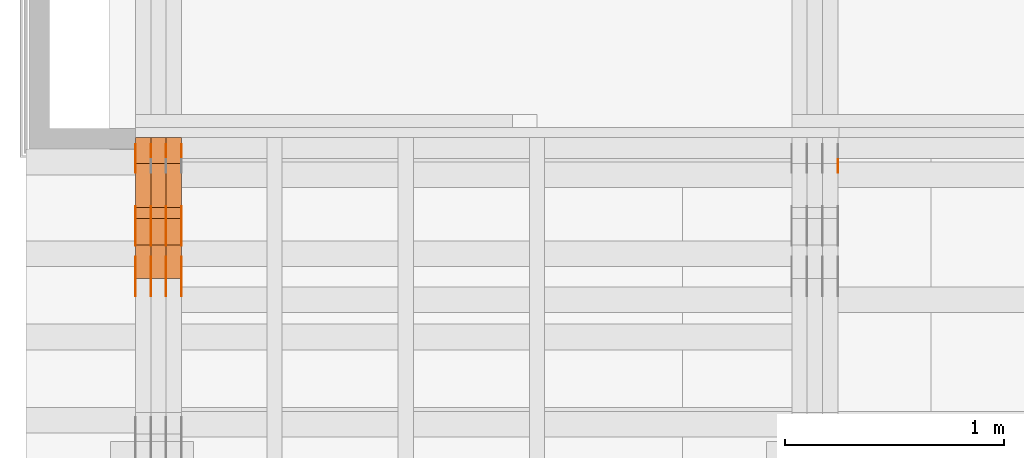
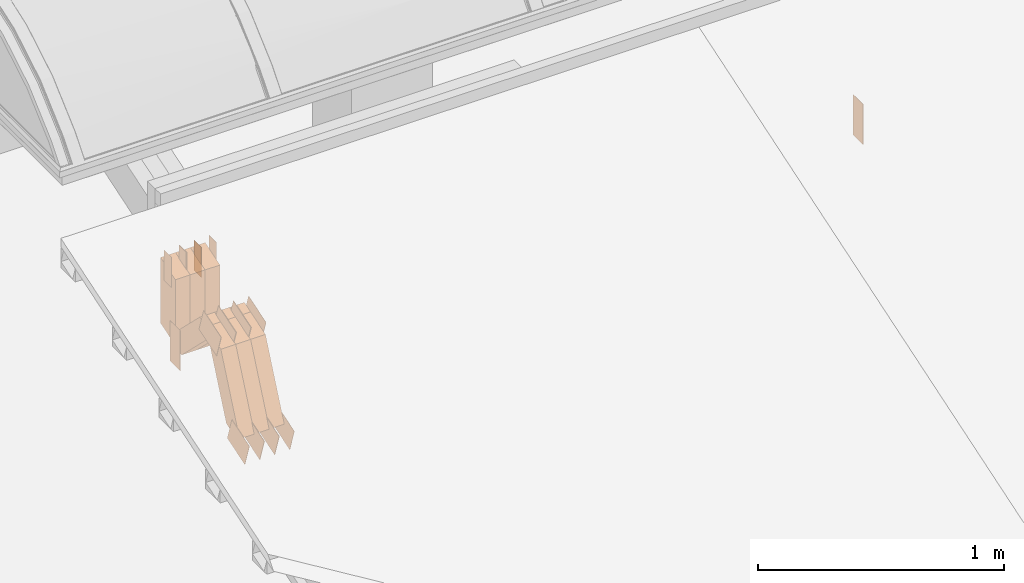
# One storey, part 77 of 385: 29 proxies.
"""IFC2X3 building model written with IfcOpenShell, lengths in millimetres."""

from ifc_helpers import new_model, entity, si_unit, converted_unit, derived_unit, direction, frame, frame_2d, origin, origin_2d_with_axis, place, context, subcontext, project, spatial, polyline, rectangle, outline, extrude, source, transform, mapped, material, type_object, type_shapes, element, save


model = new_model("IFC2X3")

# Units and contexts
model_context = context("Model", 3, precision=0.01, world=origin(), true_north=direction((6.12303176911189e-17, 1.0)))
body_context = subcontext(model_context, "Body", "Model", "MODEL_VIEW")
ifc_project = project(units=[si_unit("LENGTHUNIT", "METRE", prefix="MILLI"), si_unit("AREAUNIT", "SQUARE_METRE"), si_unit("VOLUMEUNIT", "CUBIC_METRE"), converted_unit("PLANEANGLEUNIT", "DEGREE", entity("IfcRatioMeasure", 0.0174532925199433), si_unit("PLANEANGLEUNIT", "RADIAN"), dimensions=[0, 0, 0, 0, 0, 0, 0]), si_unit("MASSUNIT", "GRAM", prefix="KILO"), derived_unit("MASSDENSITYUNIT", [(si_unit("MASSUNIT", "GRAM", prefix="KILO"), 1), (si_unit("LENGTHUNIT", "METRE"), -3)]), si_unit("TIMEUNIT", "SECOND"), si_unit("FREQUENCYUNIT", "HERTZ"), si_unit("THERMODYNAMICTEMPERATUREUNIT", "DEGREE_CELSIUS"), derived_unit("THERMALTRANSMITTANCEUNIT", [(si_unit("MASSUNIT", "GRAM", prefix="KILO"), 1), (si_unit("THERMODYNAMICTEMPERATUREUNIT", "KELVIN"), -1), (si_unit("TIMEUNIT", "SECOND"), -3)]), derived_unit("VOLUMETRICFLOWRATEUNIT", [(si_unit("LENGTHUNIT", "METRE"), 3), (si_unit("TIMEUNIT", "SECOND"), -1)]), si_unit("ELECTRICCURRENTUNIT", "AMPERE"), si_unit("ELECTRICVOLTAGEUNIT", "VOLT"), si_unit("POWERUNIT", "WATT"), si_unit("FORCEUNIT", "NEWTON", prefix="KILO"), si_unit("ILLUMINANCEUNIT", "LUX"), si_unit("LUMINOUSFLUXUNIT", "LUMEN"), si_unit("LUMINOUSINTENSITYUNIT", "CANDELA"), derived_unit("USERDEFINED", [(si_unit("MASSUNIT", "GRAM", prefix="KILO"), -1), (si_unit("LENGTHUNIT", "METRE"), -2), (si_unit("TIMEUNIT", "SECOND"), 3), (si_unit("LUMINOUSFLUXUNIT", "LUMEN"), 1)]), derived_unit("LINEARVELOCITYUNIT", [(si_unit("LENGTHUNIT", "METRE"), 1), (si_unit("TIMEUNIT", "SECOND"), -1)]), si_unit("PRESSUREUNIT", "PASCAL"), derived_unit("USERDEFINED", [(si_unit("LENGTHUNIT", "METRE"), -2), (si_unit("MASSUNIT", "GRAM", prefix="KILO"), 1), (si_unit("TIMEUNIT", "SECOND"), -2)])], contexts=[model_context])

# Site, building, storey
site_placement = place(None, origin())
site = spatial("IfcSite", under=ifc_project, at=site_placement, CompositionType="ELEMENT")
building_placement = place(site_placement, origin())
building = spatial("IfcBuilding", under=site, at=building_placement, CompositionType="ELEMENT")
storey_placement = place(building_placement, origin())
storey = spatial("IfcBuildingStorey", under=building, at=storey_placement, Name="Default", CompositionType="ELEMENT", Elevation=0.0)

# Proxies
ifc_material_1 = material(Name="IfcSurfaceStyle #71412")
building_element_proxy_type_1 = type_object("IfcBuildingElementProxyType", PredefinedType="NOTDEFINED", material=ifc_material_1)
shared_shape_1 = source(origin(), body_context, "Body", "SweptSolid", [
    extrude(rectangle(XDim=200.0, YDim=84.0, at=frame_2d((0.0, -7.105427357601e-15), x_axis=(1.0, 0.0))), frame((100.0, 42.0, 0.0), z_axis=(0.0, 0.0, 1.0), x_axis=(-1.0, 0.0, 0.0)), (0.0, 0.0, 1.0), 1.3),
])
type_shapes(building_element_proxy_type_1, [shared_shape_1])
proxy_1_placement = place(building_placement, frame((3386.29999999999, 13702.0, 3651.4150390625), z_axis=(-1.0, 0.0, 0.0), x_axis=(0.0, 0.0, -1.0)))
element("IfcBuildingElementProxy", 1, at=proxy_1_placement, inside=storey, type_object=building_element_proxy_type_1, material=ifc_material_1, context=body_context, shape_type="MappedRepresentation", body=[
    mapped(shared_shape_1, transform((0.0, 0.0, 0.0), scale=1.0)),
])
ifc_material_2 = material(Name="IfcSurfaceStyle #36695")
building_element_proxy_type_2 = type_object("IfcBuildingElementProxyType", PredefinedType="NOTDEFINED", material=ifc_material_2)
shared_shape_2 = source(origin(), body_context, "Body", "SweptSolid", [
    extrude(rectangle(XDim=200.0, YDim=84.0, at=frame_2d((0.0, -7.105427357601e-15), x_axis=(1.0, 0.0))), frame((100.0, 42.0, 0.0), z_axis=(0.0, 0.0, 1.0), x_axis=(-1.0, 0.0, 0.0)), (0.0, 0.0, 1.0), 1.29999999999999),
])
type_shapes(building_element_proxy_type_2, [shared_shape_2])
proxy_2_placement = place(building_placement, frame((175.0, 13702.0, 3651.4150390625), z_axis=(-1.0, 0.0, 0.0), x_axis=(0.0, 0.0, -1.0)))
element("IfcBuildingElementProxy", 2, at=proxy_2_placement, inside=storey, type_object=building_element_proxy_type_2, material=ifc_material_2, context=body_context, shape_type="MappedRepresentation", body=[
    mapped(shared_shape_2, transform((0.0, 0.0, 0.0), scale=1.0)),
])
ifc_material_3 = material(Name="IfcSurfaceStyle #36638")
building_element_proxy_type_3 = type_object("IfcBuildingElementProxyType", PredefinedType="NOTDEFINED", material=ifc_material_3)
shared_shape_3 = source(origin(), body_context, "Body", "SweptSolid", [
    extrude(outline(polyline([(-75.0003398116828, -59.9998507501386), (75.0003249421766, -59.9998507501386), (75.0003398116837, 59.9998507501387), (-75.0003249421775, 59.9998507501387), (-75.0003398116828, -59.9998507501386)])), frame((75.0003398116837, 60.0000773549637, 0.0), z_axis=(0.0, 0.0, 1.0), x_axis=(-1.0, 0.0, 0.0)), (0.0, 0.0, 1.0), 1.3),
])
type_shapes(building_element_proxy_type_3, [shared_shape_3])
proxy_3_placement = place(building_placement, frame((386.299999999986, 13054.73046875, 3417.8388671875), z_axis=(-1.0, 0.0, 0.0), x_axis=(0.0, 0.951056516295124, 0.309016994375039)))
element("IfcBuildingElementProxy", 3, at=proxy_3_placement, inside=storey, type_object=building_element_proxy_type_3, material=ifc_material_3, context=body_context, shape_type="MappedRepresentation", body=[
    mapped(shared_shape_3, transform((0.0, 0.0, 0.0), scale=1.0)),
])
ifc_material_4 = material(Name="IfcSurfaceStyle #36581")
building_element_proxy_type_4 = type_object("IfcBuildingElementProxyType", PredefinedType="NOTDEFINED", material=ifc_material_4)
shared_shape_4 = source(origin(), body_context, "Body", "SweptSolid", [
    extrude(outline(polyline([(-75.0003398116828, -59.9998507501386), (75.0003249421766, -59.9998507501386), (75.0003398116837, 59.9998507501387), (-75.0003249421775, 59.9998507501387), (-75.0003398116828, -59.9998507501386)])), frame((75.0003398116837, 60.0000773549637, 0.0), z_axis=(0.0, 0.0, 1.0), x_axis=(-1.0, 0.0, 0.0)), (0.0, 0.0, 1.0), 1.3),
])
type_shapes(building_element_proxy_type_4, [shared_shape_4])
proxy_4_placement = place(building_placement, frame((315.0, 13054.73046875, 3417.8388671875), z_axis=(-1.0, 0.0, 0.0), x_axis=(0.0, 0.951056516295124, 0.309016994375039)))
element("IfcBuildingElementProxy", 4, at=proxy_4_placement, inside=storey, type_object=building_element_proxy_type_4, material=ifc_material_4, context=body_context, shape_type="MappedRepresentation", body=[
    mapped(shared_shape_4, transform((0.0, 0.0, 0.0), scale=1.0)),
])
ifc_material_5 = material(Name="IfcSurfaceStyle #36524")
building_element_proxy_type_5 = type_object("IfcBuildingElementProxyType", PredefinedType="NOTDEFINED", material=ifc_material_5)
shared_shape_5 = source(origin(), body_context, "Body", "SweptSolid", [
    extrude(outline(polyline([(-75.0003398116828, -59.9998507501386), (75.0003249421766, -59.9998507501386), (75.0003398116837, 59.9998507501387), (-75.0003249421775, 59.9998507501387), (-75.0003398116828, -59.9998507501386)])), frame((75.0003398116837, 60.0000773549637, 0.0), z_axis=(0.0, 0.0, 1.0), x_axis=(-1.0, 0.0, 0.0)), (0.0, 0.0, 1.0), 1.3),
])
type_shapes(building_element_proxy_type_5, [shared_shape_5])
proxy_5_placement = place(building_placement, frame((316.299999999986, 13054.73046875, 3417.8388671875), z_axis=(-1.0, 0.0, 0.0), x_axis=(0.0, 0.951056516295124, 0.309016994375039)))
element("IfcBuildingElementProxy", 5, at=proxy_5_placement, inside=storey, type_object=building_element_proxy_type_5, material=ifc_material_5, context=body_context, shape_type="MappedRepresentation", body=[
    mapped(shared_shape_5, transform((0.0, 0.0, 0.0), scale=1.0)),
])
ifc_material_6 = material(Name="IfcSurfaceStyle #36467")
building_element_proxy_type_6 = type_object("IfcBuildingElementProxyType", PredefinedType="NOTDEFINED", material=ifc_material_6)
shared_shape_6 = source(origin(), body_context, "Body", "SweptSolid", [
    extrude(outline(polyline([(-75.0003398116828, -59.9998507501386), (75.0003249421766, -59.9998507501386), (75.0003398116837, 59.9998507501387), (-75.0003249421775, 59.9998507501387), (-75.0003398116828, -59.9998507501386)])), frame((75.0003398116837, 60.0000773549637, 0.0), z_axis=(0.0, 0.0, 1.0), x_axis=(-1.0, 0.0, 0.0)), (0.0, 0.0, 1.0), 1.29999999999999),
])
type_shapes(building_element_proxy_type_6, [shared_shape_6])
proxy_6_placement = place(building_placement, frame((245.0, 13054.73046875, 3417.8388671875), z_axis=(-1.0, 0.0, 0.0), x_axis=(0.0, 0.951056516295124, 0.309016994375039)))
element("IfcBuildingElementProxy", 6, at=proxy_6_placement, inside=storey, type_object=building_element_proxy_type_6, material=ifc_material_6, context=body_context, shape_type="MappedRepresentation", body=[
    mapped(shared_shape_6, transform((0.0, 0.0, 0.0), scale=1.0)),
])
ifc_material_7 = material(Name="IfcSurfaceStyle #36410")
building_element_proxy_type_7 = type_object("IfcBuildingElementProxyType", PredefinedType="NOTDEFINED", material=ifc_material_7)
shared_shape_7 = source(origin(), body_context, "Body", "SweptSolid", [
    extrude(outline(polyline([(-75.0003398116828, -59.9998507501386), (75.0003249421766, -59.9998507501386), (75.0003398116837, 59.9998507501387), (-75.0003249421775, 59.9998507501387), (-75.0003398116828, -59.9998507501386)])), frame((75.0003398116837, 60.0000773549637, 0.0), z_axis=(0.0, 0.0, 1.0), x_axis=(-1.0, 0.0, 0.0)), (0.0, 0.0, 1.0), 1.29999999999999),
])
type_shapes(building_element_proxy_type_7, [shared_shape_7])
proxy_7_placement = place(building_placement, frame((246.299999999986, 13054.73046875, 3417.8388671875), z_axis=(-1.0, 0.0, 0.0), x_axis=(0.0, 0.951056516295124, 0.309016994375039)))
element("IfcBuildingElementProxy", 7, at=proxy_7_placement, inside=storey, type_object=building_element_proxy_type_7, material=ifc_material_7, context=body_context, shape_type="MappedRepresentation", body=[
    mapped(shared_shape_7, transform((0.0, 0.0, 0.0), scale=1.0)),
])
ifc_material_8 = material(Name="IfcSurfaceStyle #36353")
building_element_proxy_type_8 = type_object("IfcBuildingElementProxyType", PredefinedType="NOTDEFINED", material=ifc_material_8)
shared_shape_8 = source(origin(), body_context, "Body", "SweptSolid", [
    extrude(outline(polyline([(-75.0003398116828, -59.9998507501386), (75.0003249421766, -59.9998507501386), (75.0003398116837, 59.9998507501387), (-75.0003249421775, 59.9998507501387), (-75.0003398116828, -59.9998507501386)])), frame((75.0003398116837, 60.0000773549637, 0.0), z_axis=(0.0, 0.0, 1.0), x_axis=(-1.0, 0.0, 0.0)), (0.0, 0.0, 1.0), 1.29999999999999),
])
type_shapes(building_element_proxy_type_8, [shared_shape_8])
proxy_8_placement = place(building_placement, frame((175.0, 13054.73046875, 3417.8388671875), z_axis=(-1.0, 0.0, 0.0), x_axis=(0.0, 0.951056516295124, 0.309016994375039)))
element("IfcBuildingElementProxy", 8, at=proxy_8_placement, inside=storey, type_object=building_element_proxy_type_8, material=ifc_material_8, context=body_context, shape_type="MappedRepresentation", body=[
    mapped(shared_shape_8, transform((0.0, 0.0, 0.0), scale=1.0)),
])
ifc_material_9 = material(Name="IfcSurfaceStyle #28772")
building_element_proxy_type_9 = type_object("IfcBuildingElementProxyType", PredefinedType="NOTDEFINED", material=ifc_material_9)
shared_shape_9 = source(origin(), body_context, "Body", "SweptSolid", [
    extrude(outline(polyline([(-74.999875428623, -60.0000016373506), (74.9998605591059, -60.0000016373506), (74.9998754286239, 60.0000016373506), (-74.9998605591068, 60.0000016373506), (-74.999875428623, -60.0000016373506)])), frame((75.0002691827262, 60.0000190504561, 0.0), z_axis=(0.0, 0.0, 1.0), x_axis=(-1.0, 0.0, 0.0)), (0.0, 0.0, 1.0), 1.3),
])
type_shapes(building_element_proxy_type_9, [shared_shape_9])
proxy_9_placement = place(building_placement, frame((386.299999999986, 13285.0865109705, 3819.37496637467), z_axis=(-1.0, 0.0, 0.0), x_axis=(0.0, 0.951056516295154, 0.309016994374948)))
element("IfcBuildingElementProxy", 9, at=proxy_9_placement, inside=storey, type_object=building_element_proxy_type_9, material=ifc_material_9, context=body_context, shape_type="MappedRepresentation", body=[
    mapped(shared_shape_9, transform((0.0, 0.0, 0.0), scale=1.0)),
])
ifc_material_10 = material(Name="IfcSurfaceStyle #28715")
building_element_proxy_type_10 = type_object("IfcBuildingElementProxyType", PredefinedType="NOTDEFINED", material=ifc_material_10)
shared_shape_10 = source(origin(), body_context, "Body", "SweptSolid", [
    extrude(outline(polyline([(-74.999875428623, -60.0000016373506), (74.9998605591059, -60.0000016373506), (74.9998754286239, 60.0000016373506), (-74.9998605591068, 60.0000016373506), (-74.999875428623, -60.0000016373506)])), frame((75.0002691827262, 60.0000190504561, 0.0), z_axis=(0.0, 0.0, 1.0), x_axis=(-1.0, 0.0, 0.0)), (0.0, 0.0, 1.0), 1.3),
])
type_shapes(building_element_proxy_type_10, [shared_shape_10])
proxy_10_placement = place(building_placement, frame((315.0, 13285.0865109705, 3819.37496637467), z_axis=(-1.0, 0.0, 0.0), x_axis=(0.0, 0.951056516295154, 0.309016994374948)))
element("IfcBuildingElementProxy", 10, at=proxy_10_placement, inside=storey, type_object=building_element_proxy_type_10, material=ifc_material_10, context=body_context, shape_type="MappedRepresentation", body=[
    mapped(shared_shape_10, transform((0.0, 0.0, 0.0), scale=1.0)),
])
ifc_material_11 = material(Name="IfcSurfaceStyle #28658")
building_element_proxy_type_11 = type_object("IfcBuildingElementProxyType", PredefinedType="NOTDEFINED", material=ifc_material_11)
shared_shape_11 = source(origin(), body_context, "Body", "SweptSolid", [
    extrude(outline(polyline([(-74.999875428623, -60.0000016373506), (74.9998605591059, -60.0000016373506), (74.9998754286239, 60.0000016373506), (-74.9998605591068, 60.0000016373506), (-74.999875428623, -60.0000016373506)])), frame((75.0002691827262, 60.0000190504561, 0.0), z_axis=(0.0, 0.0, 1.0), x_axis=(-1.0, 0.0, 0.0)), (0.0, 0.0, 1.0), 1.3),
])
type_shapes(building_element_proxy_type_11, [shared_shape_11])
proxy_11_placement = place(building_placement, frame((316.299999999986, 13285.0865109705, 3819.37496637467), z_axis=(-1.0, 0.0, 0.0), x_axis=(0.0, 0.951056516295154, 0.309016994374948)))
element("IfcBuildingElementProxy", 11, at=proxy_11_placement, inside=storey, type_object=building_element_proxy_type_11, material=ifc_material_11, context=body_context, shape_type="MappedRepresentation", body=[
    mapped(shared_shape_11, transform((0.0, 0.0, 0.0), scale=1.0)),
])
ifc_material_12 = material(Name="IfcSurfaceStyle #28601")
building_element_proxy_type_12 = type_object("IfcBuildingElementProxyType", PredefinedType="NOTDEFINED", material=ifc_material_12)
shared_shape_12 = source(origin(), body_context, "Body", "SweptSolid", [
    extrude(outline(polyline([(-74.999875428623, -60.0000016373506), (74.9998605591059, -60.0000016373506), (74.9998754286239, 60.0000016373506), (-74.9998605591068, 60.0000016373506), (-74.999875428623, -60.0000016373506)])), frame((75.0002691827262, 60.0000190504561, 0.0), z_axis=(0.0, 0.0, 1.0), x_axis=(-1.0, 0.0, 0.0)), (0.0, 0.0, 1.0), 1.29999999999999),
])
type_shapes(building_element_proxy_type_12, [shared_shape_12])
proxy_12_placement = place(building_placement, frame((245.0, 13285.0865109705, 3819.37496637467), z_axis=(-1.0, 0.0, 0.0), x_axis=(0.0, 0.951056516295154, 0.309016994374948)))
element("IfcBuildingElementProxy", 12, at=proxy_12_placement, inside=storey, type_object=building_element_proxy_type_12, material=ifc_material_12, context=body_context, shape_type="MappedRepresentation", body=[
    mapped(shared_shape_12, transform((0.0, 0.0, 0.0), scale=1.0)),
])
ifc_material_13 = material(Name="IfcSurfaceStyle #28544")
building_element_proxy_type_13 = type_object("IfcBuildingElementProxyType", PredefinedType="NOTDEFINED", material=ifc_material_13)
shared_shape_13 = source(origin(), body_context, "Body", "SweptSolid", [
    extrude(outline(polyline([(-74.999875428623, -60.0000016373506), (74.9998605591059, -60.0000016373506), (74.9998754286239, 60.0000016373506), (-74.9998605591068, 60.0000016373506), (-74.999875428623, -60.0000016373506)])), frame((75.0002691827262, 60.0000190504561, 0.0), z_axis=(0.0, 0.0, 1.0), x_axis=(-1.0, 0.0, 0.0)), (0.0, 0.0, 1.0), 1.29999999999999),
])
type_shapes(building_element_proxy_type_13, [shared_shape_13])
proxy_13_placement = place(building_placement, frame((246.299999999986, 13285.0865109705, 3819.37496637467), z_axis=(-1.0, 0.0, 0.0), x_axis=(0.0, 0.951056516295154, 0.309016994374948)))
element("IfcBuildingElementProxy", 13, at=proxy_13_placement, inside=storey, type_object=building_element_proxy_type_13, material=ifc_material_13, context=body_context, shape_type="MappedRepresentation", body=[
    mapped(shared_shape_13, transform((0.0, 0.0, 0.0), scale=1.0)),
])
ifc_material_14 = material(Name="IfcSurfaceStyle #28487")
building_element_proxy_type_14 = type_object("IfcBuildingElementProxyType", PredefinedType="NOTDEFINED", material=ifc_material_14)
shared_shape_14 = source(origin(), body_context, "Body", "SweptSolid", [
    extrude(outline(polyline([(-74.999875428623, -60.0000016373506), (74.9998605591059, -60.0000016373506), (74.9998754286239, 60.0000016373506), (-74.9998605591068, 60.0000016373506), (-74.999875428623, -60.0000016373506)])), frame((75.0002691827262, 60.0000190504561, 0.0), z_axis=(0.0, 0.0, 1.0), x_axis=(-1.0, 0.0, 0.0)), (0.0, 0.0, 1.0), 1.29999999999999),
])
type_shapes(building_element_proxy_type_14, [shared_shape_14])
proxy_14_placement = place(building_placement, frame((175.0, 13285.0865109705, 3819.37496637467), z_axis=(-1.0, 0.0, 0.0), x_axis=(0.0, 0.951056516295154, 0.309016994374948)))
element("IfcBuildingElementProxy", 14, at=proxy_14_placement, inside=storey, type_object=building_element_proxy_type_14, material=ifc_material_14, context=body_context, shape_type="MappedRepresentation", body=[
    mapped(shared_shape_14, transform((0.0, 0.0, 0.0), scale=1.0)),
])
ifc_material_15 = material(Name="IfcSurfaceStyle #28088")
building_element_proxy_type_15 = type_object("IfcBuildingElementProxyType", PredefinedType="NOTDEFINED", material=ifc_material_15)
shared_shape_15 = source(origin(), body_context, "Body", "SweptSolid", [
    extrude(rectangle(XDim=150.0, YDim=60.0, at=origin_2d_with_axis()), frame((75.0000705696166, 30.0, 0.0), z_axis=(0.0, 0.0, 1.0), x_axis=(-1.0, 0.0, 0.0)), (0.0, 0.0, 1.0), 1.3),
])
type_shapes(building_element_proxy_type_15, [shared_shape_15])
proxy_15_placement = place(building_placement, frame((386.299999999986, 13750.0, 3972.59919166337), z_axis=(-1.0, 0.0, 0.0), x_axis=(0.0, 0.0, -1.0)))
element("IfcBuildingElementProxy", 15, at=proxy_15_placement, inside=storey, type_object=building_element_proxy_type_15, material=ifc_material_15, context=body_context, shape_type="MappedRepresentation", body=[
    mapped(shared_shape_15, transform((0.0, 0.0, 0.0), scale=1.0)),
])
ifc_material_16 = material(Name="IfcSurfaceStyle #28031")
building_element_proxy_type_16 = type_object("IfcBuildingElementProxyType", PredefinedType="NOTDEFINED", material=ifc_material_16)
shared_shape_16 = source(origin(), body_context, "Body", "SweptSolid", [
    extrude(rectangle(XDim=150.0, YDim=60.0, at=origin_2d_with_axis()), frame((75.0000705696166, 30.0, 0.0), z_axis=(0.0, 0.0, 1.0), x_axis=(-1.0, 0.0, 0.0)), (0.0, 0.0, 1.0), 1.3),
])
type_shapes(building_element_proxy_type_16, [shared_shape_16])
proxy_16_placement = place(building_placement, frame((315.0, 13750.0, 3972.59919166337), z_axis=(-1.0, 0.0, 0.0), x_axis=(0.0, 0.0, -1.0)))
element("IfcBuildingElementProxy", 16, at=proxy_16_placement, inside=storey, type_object=building_element_proxy_type_16, material=ifc_material_16, context=body_context, shape_type="MappedRepresentation", body=[
    mapped(shared_shape_16, transform((0.0, 0.0, 0.0), scale=1.0)),
])
ifc_material_17 = material(Name="IfcSurfaceStyle #27974")
building_element_proxy_type_17 = type_object("IfcBuildingElementProxyType", PredefinedType="NOTDEFINED", material=ifc_material_17)
shared_shape_17 = source(origin(), body_context, "Body", "SweptSolid", [
    extrude(rectangle(XDim=150.0, YDim=60.0, at=origin_2d_with_axis()), frame((75.0000705696166, 30.0, 0.0), z_axis=(0.0, 0.0, 1.0), x_axis=(-1.0, 0.0, 0.0)), (0.0, 0.0, 1.0), 1.3),
])
type_shapes(building_element_proxy_type_17, [shared_shape_17])
proxy_17_placement = place(building_placement, frame((316.299999999986, 13750.0, 3972.59919166337), z_axis=(-1.0, 0.0, 0.0), x_axis=(0.0, 0.0, -1.0)))
element("IfcBuildingElementProxy", 17, at=proxy_17_placement, inside=storey, type_object=building_element_proxy_type_17, material=ifc_material_17, context=body_context, shape_type="MappedRepresentation", body=[
    mapped(shared_shape_17, transform((0.0, 0.0, 0.0), scale=1.0)),
])
ifc_material_18 = material(Name="IfcSurfaceStyle #27917")
building_element_proxy_type_18 = type_object("IfcBuildingElementProxyType", PredefinedType="NOTDEFINED", material=ifc_material_18)
shared_shape_18 = source(origin(), body_context, "Body", "SweptSolid", [
    extrude(rectangle(XDim=150.0, YDim=60.0, at=origin_2d_with_axis()), frame((75.0000705696166, 30.0, 0.0), z_axis=(0.0, 0.0, 1.0), x_axis=(-1.0, 0.0, 0.0)), (0.0, 0.0, 1.0), 1.29999999999999),
])
type_shapes(building_element_proxy_type_18, [shared_shape_18])
proxy_18_placement = place(building_placement, frame((245.0, 13750.0, 3972.59919166337), z_axis=(-1.0, 0.0, 0.0), x_axis=(0.0, 0.0, -1.0)))
element("IfcBuildingElementProxy", 18, at=proxy_18_placement, inside=storey, type_object=building_element_proxy_type_18, material=ifc_material_18, context=body_context, shape_type="MappedRepresentation", body=[
    mapped(shared_shape_18, transform((0.0, 0.0, 0.0), scale=1.0)),
])
ifc_material_19 = material(Name="IfcSurfaceStyle #27860")
building_element_proxy_type_19 = type_object("IfcBuildingElementProxyType", PredefinedType="NOTDEFINED", material=ifc_material_19)
shared_shape_19 = source(origin(), body_context, "Body", "SweptSolid", [
    extrude(rectangle(XDim=150.0, YDim=60.0, at=origin_2d_with_axis()), frame((75.0000705696166, 30.0, 0.0), z_axis=(0.0, 0.0, 1.0), x_axis=(-1.0, 0.0, 0.0)), (0.0, 0.0, 1.0), 1.29999999999999),
])
type_shapes(building_element_proxy_type_19, [shared_shape_19])
proxy_19_placement = place(building_placement, frame((246.299999999986, 13750.0, 3972.59919166337), z_axis=(-1.0, 0.0, 0.0), x_axis=(0.0, 0.0, -1.0)))
element("IfcBuildingElementProxy", 19, at=proxy_19_placement, inside=storey, type_object=building_element_proxy_type_19, material=ifc_material_19, context=body_context, shape_type="MappedRepresentation", body=[
    mapped(shared_shape_19, transform((0.0, 0.0, 0.0), scale=1.0)),
])
ifc_material_20 = material(Name="IfcSurfaceStyle #27803")
building_element_proxy_type_20 = type_object("IfcBuildingElementProxyType", PredefinedType="NOTDEFINED", material=ifc_material_20)
shared_shape_20 = source(origin(), body_context, "Body", "SweptSolid", [
    extrude(rectangle(XDim=150.0, YDim=60.0, at=origin_2d_with_axis()), frame((75.0000705696166, 30.0, 0.0), z_axis=(0.0, 0.0, 1.0), x_axis=(-1.0, 0.0, 0.0)), (0.0, 0.0, 1.0), 1.29999999999999),
])
type_shapes(building_element_proxy_type_20, [shared_shape_20])
proxy_20_placement = place(building_placement, frame((175.0, 13750.0, 3972.59919166337), z_axis=(-1.0, 0.0, 0.0), x_axis=(0.0, 0.0, -1.0)))
element("IfcBuildingElementProxy", 20, at=proxy_20_placement, inside=storey, type_object=building_element_proxy_type_20, material=ifc_material_20, context=body_context, shape_type="MappedRepresentation", body=[
    mapped(shared_shape_20, transform((0.0, 0.0, 0.0), scale=1.0)),
])
ifc_material_21 = material(Name="IfcSurfaceStyle #18602")
building_element_proxy_type_21 = type_object("IfcBuildingElementProxyType", Name="T1-W49 18600", PredefinedType="NOTDEFINED", material=ifc_material_21)
shared_shape_21 = source(origin(), body_context, "Body", "SweptSolid", [
    extrude(outline(polyline([(-155.175867306415, -47.4997478409253), (152.310664695054, -47.4997478409253), (170.496756790954, -6.14570120142345e-05), (145.70957993751, 47.4998092979374), (-133.37808995724, 47.4998092979373), (-179.963044159863, -6.14570120298391e-05), (-155.175867306415, -47.4997478409253)])), frame((170.496756790954, 47.5001152140455, 0.0), z_axis=(0.0, 0.0, 1.0), x_axis=(-1.0, 0.0, 0.0)), (0.0, 0.0, 1.0), 70.0),
])
type_shapes(building_element_proxy_type_21, [shared_shape_21])
proxy_21_placement = place(building_placement, frame((385.0, 13443.048524104, 3830.71841973934), z_axis=(-1.0, 0.0, 0.0), x_axis=(0.0, 0.713950095632063, -0.700196587357413)))
element("IfcBuildingElementProxy", 21, at=proxy_21_placement, inside=storey, type_object=building_element_proxy_type_21, material=ifc_material_21, Name="T1-W49", context=body_context, shape_type="MappedRepresentation", body=[
    mapped(shared_shape_21, transform((0.0, 0.0, 0.0), scale=1.0)),
])
ifc_material_22 = material(Name="IfcSurfaceStyle #18527")
building_element_proxy_type_22 = type_object("IfcBuildingElementProxyType", Name="T1-W49 18525", PredefinedType="NOTDEFINED", material=ifc_material_22)
shared_shape_22 = source(origin(), body_context, "Body", "SweptSolid", [
    extrude(outline(polyline([(-155.175867306415, -47.4997478409253), (152.310664695054, -47.4997478409253), (170.496756790954, -6.14570120142345e-05), (145.70957993751, 47.4998092979374), (-133.37808995724, 47.4998092979373), (-179.963044159863, -6.14570120298391e-05), (-155.175867306415, -47.4997478409253)])), frame((170.496756790954, 47.5001152140455, 0.0), z_axis=(0.0, 0.0, 1.0), x_axis=(-1.0, 0.0, 0.0)), (0.0, 0.0, 1.0), 70.0),
])
type_shapes(building_element_proxy_type_22, [shared_shape_22])
proxy_22_placement = place(building_placement, frame((315.0, 13443.048524104, 3830.71841973934), z_axis=(-1.0, 0.0, 0.0), x_axis=(0.0, 0.713950095632063, -0.700196587357413)))
element("IfcBuildingElementProxy", 22, at=proxy_22_placement, inside=storey, type_object=building_element_proxy_type_22, material=ifc_material_22, Name="T1-W49", context=body_context, shape_type="MappedRepresentation", body=[
    mapped(shared_shape_22, transform((0.0, 0.0, 0.0), scale=1.0)),
])
ifc_material_23 = material(Name="IfcSurfaceStyle #18452")
building_element_proxy_type_23 = type_object("IfcBuildingElementProxyType", Name="T1-W49 18450", PredefinedType="NOTDEFINED", material=ifc_material_23)
shared_shape_23 = source(origin(), body_context, "Body", "SweptSolid", [
    extrude(outline(polyline([(-155.175867306415, -47.4997478409253), (152.310664695054, -47.4997478409253), (170.496756790954, -6.14570120142345e-05), (145.70957993751, 47.4998092979374), (-133.37808995724, 47.4998092979373), (-179.963044159863, -6.14570120298391e-05), (-155.175867306415, -47.4997478409253)])), frame((170.496756790954, 47.5001152140455, 0.0), z_axis=(0.0, 0.0, 1.0), x_axis=(-1.0, 0.0, 0.0)), (0.0, 0.0, 1.0), 70.0),
])
type_shapes(building_element_proxy_type_23, [shared_shape_23])
proxy_23_placement = place(building_placement, frame((245.0, 13443.048524104, 3830.71841973934), z_axis=(-1.0, 0.0, 0.0), x_axis=(0.0, 0.713950095632063, -0.700196587357413)))
element("IfcBuildingElementProxy", 23, at=proxy_23_placement, inside=storey, type_object=building_element_proxy_type_23, material=ifc_material_23, Name="T1-W49", context=body_context, shape_type="MappedRepresentation", body=[
    mapped(shared_shape_23, transform((0.0, 0.0, 0.0), scale=1.0)),
])
ifc_material_24 = material(Name="IfcSurfaceStyle #18152")
building_element_proxy_type_24 = type_object("IfcBuildingElementProxyType", Name="T1-W1 18150", PredefinedType="NOTDEFINED", material=ifc_material_24)
shared_shape_24 = source(origin(), body_context, "Body", "SweptSolid", [
    extrude(outline(polyline([(-182.839782714844, -60.0), (143.849426269531, -60.0), (182.839660644531, 60.0), (-143.849304199219, 60.0), (-182.839782714844, -60.0)])), frame((182.839674685549, 60.0, 0.0), z_axis=(0.0, 0.0, 1.0), x_axis=(-1.0, 0.0, 0.0)), (0.0, 0.0, 1.0), 70.0),
])
type_shapes(building_element_proxy_type_24, [shared_shape_24])
proxy_24_placement = place(building_placement, frame((385.0, 13660.0, 3551.41502502148), z_axis=(-1.0, 0.0, 0.0), x_axis=(0.0, 0.0, 1.0)))
element("IfcBuildingElementProxy", 24, at=proxy_24_placement, inside=storey, type_object=building_element_proxy_type_24, material=ifc_material_24, Name="T1-W1", context=body_context, shape_type="MappedRepresentation", body=[
    mapped(shared_shape_24, transform((0.0, 0.0, 0.0), scale=1.0)),
])
ifc_material_25 = material(Name="IfcSurfaceStyle #18095")
building_element_proxy_type_25 = type_object("IfcBuildingElementProxyType", Name="T1-W1 18093", PredefinedType="NOTDEFINED", material=ifc_material_25)
shared_shape_25 = source(origin(), body_context, "Body", "SweptSolid", [
    extrude(outline(polyline([(-182.839782714844, -60.0), (143.849426269531, -60.0), (182.839660644531, 60.0), (-143.849304199219, 60.0), (-182.839782714844, -60.0)])), frame((182.839674685549, 60.0, 0.0), z_axis=(0.0, 0.0, 1.0), x_axis=(-1.0, 0.0, 0.0)), (0.0, 0.0, 1.0), 70.0),
])
type_shapes(building_element_proxy_type_25, [shared_shape_25])
proxy_25_placement = place(building_placement, frame((315.0, 13660.0, 3551.41502502148), z_axis=(-1.0, 0.0, 0.0), x_axis=(0.0, 0.0, 1.0)))
element("IfcBuildingElementProxy", 25, at=proxy_25_placement, inside=storey, type_object=building_element_proxy_type_25, material=ifc_material_25, Name="T1-W1", context=body_context, shape_type="MappedRepresentation", body=[
    mapped(shared_shape_25, transform((0.0, 0.0, 0.0), scale=1.0)),
])
ifc_material_26 = material(Name="IfcSurfaceStyle #18038")
building_element_proxy_type_26 = type_object("IfcBuildingElementProxyType", Name="T1-W1 18036", PredefinedType="NOTDEFINED", material=ifc_material_26)
shared_shape_26 = source(origin(), body_context, "Body", "SweptSolid", [
    extrude(outline(polyline([(-182.839782714844, -60.0), (143.849426269531, -60.0), (182.839660644531, 60.0), (-143.849304199219, 60.0), (-182.839782714844, -60.0)])), frame((182.839674685549, 60.0, 0.0), z_axis=(0.0, 0.0, 1.0), x_axis=(-1.0, 0.0, 0.0)), (0.0, 0.0, 1.0), 70.0),
])
type_shapes(building_element_proxy_type_26, [shared_shape_26])
proxy_26_placement = place(building_placement, frame((245.0, 13660.0, 3551.41502502148), z_axis=(-1.0, 0.0, 0.0), x_axis=(0.0, 0.0, 1.0)))
element("IfcBuildingElementProxy", 26, at=proxy_26_placement, inside=storey, type_object=building_element_proxy_type_26, material=ifc_material_26, Name="T1-W1", context=body_context, shape_type="MappedRepresentation", body=[
    mapped(shared_shape_26, transform((0.0, 0.0, 0.0), scale=1.0)),
])
ifc_material_27 = material(Name="IfcSurfaceStyle #17612")
building_element_proxy_type_27 = type_object("IfcBuildingElementProxyType", Name="T1-W42 17610", PredefinedType="NOTDEFINED", material=ifc_material_27)
shared_shape_27 = source(origin(), body_context, "Body", "SweptSolid", [
    extrude(outline(polyline([(-284.837590197601, -47.4997543607933), (129.95880168156, -47.4997543607933), (171.972324990451, 0.000162623346093338), (183.717007105413, 47.4996730491203), (-200.810543579822, 47.4996730491203), (-284.837590197601, -47.4997543607933)])), frame((183.717155718752, 47.4999821655365, 0.0), z_axis=(0.0, 0.0, 1.0), x_axis=(-1.0, 0.0, 0.0)), (0.0, 0.0, 1.0), 70.0),
])
type_shapes(building_element_proxy_type_27, [shared_shape_27])
proxy_27_placement = place(building_placement, frame((385.0, 13135.8834463264, 3404.958483022), z_axis=(-1.0, 0.0, 0.0), x_axis=(0.0, 0.398630596470292, 0.917111578575769)))
element("IfcBuildingElementProxy", 27, at=proxy_27_placement, inside=storey, type_object=building_element_proxy_type_27, material=ifc_material_27, Name="T1-W42", context=body_context, shape_type="MappedRepresentation", body=[
    mapped(shared_shape_27, transform((0.0, 0.0, 0.0), scale=1.0)),
])
ifc_material_28 = material(Name="IfcSurfaceStyle #17546")
building_element_proxy_type_28 = type_object("IfcBuildingElementProxyType", Name="T1-W42 17544", PredefinedType="NOTDEFINED", material=ifc_material_28)
shared_shape_28 = source(origin(), body_context, "Body", "SweptSolid", [
    extrude(outline(polyline([(-284.837590197601, -47.4997543607933), (129.95880168156, -47.4997543607933), (171.972324990451, 0.000162623346093338), (183.717007105413, 47.4996730491203), (-200.810543579822, 47.4996730491203), (-284.837590197601, -47.4997543607933)])), frame((183.717155718752, 47.4999821655365, 0.0), z_axis=(0.0, 0.0, 1.0), x_axis=(-1.0, 0.0, 0.0)), (0.0, 0.0, 1.0), 70.0),
])
type_shapes(building_element_proxy_type_28, [shared_shape_28])
proxy_28_placement = place(building_placement, frame((315.0, 13135.8834463264, 3404.958483022), z_axis=(-1.0, 0.0, 0.0), x_axis=(0.0, 0.398630596470292, 0.917111578575769)))
element("IfcBuildingElementProxy", 28, at=proxy_28_placement, inside=storey, type_object=building_element_proxy_type_28, material=ifc_material_28, Name="T1-W42", context=body_context, shape_type="MappedRepresentation", body=[
    mapped(shared_shape_28, transform((0.0, 0.0, 0.0), scale=1.0)),
])
ifc_material_29 = material(Name="IfcSurfaceStyle #17480")
building_element_proxy_type_29 = type_object("IfcBuildingElementProxyType", Name="T1-W42 17478", PredefinedType="NOTDEFINED", material=ifc_material_29)
shared_shape_29 = source(origin(), body_context, "Body", "SweptSolid", [
    extrude(outline(polyline([(-284.837590197601, -47.4997543607933), (129.95880168156, -47.4997543607933), (171.972324990451, 0.000162623346093338), (183.717007105413, 47.4996730491203), (-200.810543579822, 47.4996730491203), (-284.837590197601, -47.4997543607933)])), frame((183.717155718752, 47.4999821655365, 0.0), z_axis=(0.0, 0.0, 1.0), x_axis=(-1.0, 0.0, 0.0)), (0.0, 0.0, 1.0), 70.0),
])
type_shapes(building_element_proxy_type_29, [shared_shape_29])
proxy_29_placement = place(building_placement, frame((245.0, 13135.8834463264, 3404.958483022), z_axis=(-1.0, 0.0, 0.0), x_axis=(0.0, 0.398630596470292, 0.917111578575769)))
element("IfcBuildingElementProxy", 29, at=proxy_29_placement, inside=storey, type_object=building_element_proxy_type_29, material=ifc_material_29, Name="T1-W42", context=body_context, shape_type="MappedRepresentation", body=[
    mapped(shared_shape_29, transform((0.0, 0.0, 0.0), scale=1.0)),
])

save(model, "model.ifc")
